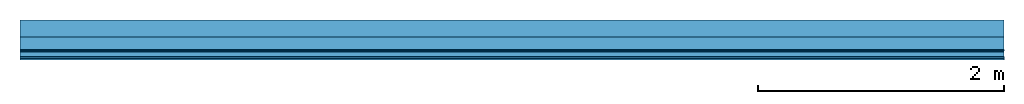
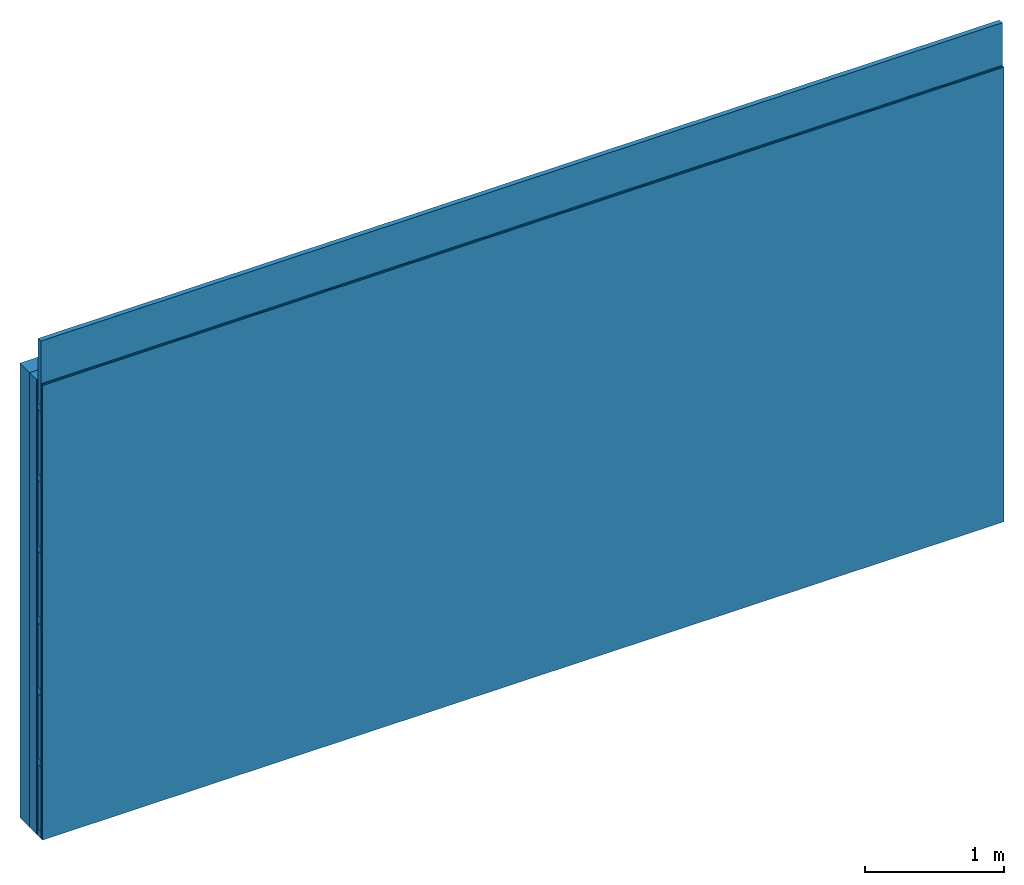
# One storey: 4 plates, 3 members, 1 element without a shape of its own.
"""IFC4 building model written with IfcOpenShell, lengths in metres."""

from ifc_helpers import new_model, si_unit, derived_unit, direction, frame, frame_2d, origin, origin_with_axes, place, context, project, spatial, rectangle, extrude, material, layer, layer_set, type_object, element, aggregate, save


model = new_model("IFC4")

# Units and contexts
plan_context = context("Plan", 3, precision=1e-05, world=origin(), true_north=direction((0.0, 1.0)))
model_context = context("Model", 3, precision=1e-05, world=origin(), true_north=direction((0.0, 1.0)))
ifc_project = project(units=[si_unit("LENGTHUNIT", "METRE"), derived_unit("SOUNDPRESSUREUNIT", [(si_unit("PRESSUREUNIT", "PASCAL", prefix="MICRO"), 0)]), si_unit("ENERGYUNIT", "JOULE", prefix="MEGA"), si_unit("MASSUNIT", "GRAM", prefix="KILO"), derived_unit("THERMALTRANSMITTANCEUNIT", [(si_unit("POWERUNIT", "WATT"), 1), (si_unit("AREAUNIT", "SQUARE_METRE"), -1), (si_unit("THERMODYNAMICTEMPERATUREUNIT", "KELVIN"), -1)]), derived_unit("AREADENSITYUNIT", [(si_unit("MASSUNIT", "GRAM", prefix="KILO"), 1), (si_unit("AREAUNIT", "SQUARE_METRE"), -1)]), derived_unit("USERDEFINED", [(si_unit("ENERGYUNIT", "JOULE", prefix="MEGA"), 1), (si_unit("AREAUNIT", "SQUARE_METRE"), -1)])], contexts=[plan_context, model_context])

# Site, building, storey
site = spatial("IfcSite", under=ifc_project)
building_placement = place(None, origin())
building = spatial("IfcBuilding", under=site, at=building_placement)
storey_placement = place(building_placement, origin())
storey = spatial("IfcBuildingStorey", under=building, at=storey_placement)

# Wall, members, plates
ifc_material_1 = material(Category="10.008")
ifc_layer_1 = layer(ifc_material_1, 0.14, Name="outside 1st layer")
ifc_material_2 = material(Name="of the art")
ifc_layer_2 = layer(ifc_material_2, 0.0, Name="Bond")
ifc_layer_3 = layer(None, 0.1, Name="Support")
ifc_material_3 = material(Name="Air")
ifc_layer_4 = layer(ifc_material_3, 0.01, Name="Coupling")
ifc_layer_5 = layer(None, 0.05, Name="Battens / profiles")
ifc_material_4 = material(Category="03.008")
ifc_layer_6 = layer(ifc_material_4, 0.0125, Name="Covering 1st layer")
ifc_layer_7 = layer(ifc_material_4, 0.0125, Name="Covering 2nd layer")
ifc_layer_set = layer_set([ifc_layer_1, ifc_layer_2, ifc_layer_3, ifc_layer_4, ifc_layer_5, ifc_layer_6, ifc_layer_7])
wall_type = type_object("IfcWallType", Name="D1197", PredefinedType="NOTDEFINED", material=ifc_layer_set)
wall_placement = place(None, frame((0.0, 0.0, 0.0), z_axis=(0.0, -1.0, 0.0), x_axis=(1.0, 0.0, 0.0)))
wall = element("IfcWall", 1, at=wall_placement, inside=storey, type_object=wall_type, material=ifc_layer_set, Name="Wall #1")
ifc_material_5 = material(Name="OSB")
member_1_placement = place(wall_placement, origin())
member_1 = element("IfcMember", 2, at=member_1_placement, material=ifc_material_5, Name="Support", context=plan_context, shape_type="SweptSolid", body=[
    extrude(rectangle(XDim=1.0, YDim=0.1, at=frame_2d((0.5, 0.05), x_axis=(1.0, 0.0))), frame((0.0, 4.0, 0.14), z_axis=(0.0, -1.0, 0.0), x_axis=(1.0, 0.0, 0.0)), (0.0, 0.0, 1.0), 4.0),
    extrude(rectangle(XDim=1.0, YDim=0.1, at=frame_2d((0.5, 0.05), x_axis=(1.0, 0.0))), frame((1.0, 4.0, 0.14), z_axis=(0.0, -1.0, 0.0), x_axis=(1.0, 0.0, 0.0)), (0.0, 0.0, 1.0), 4.0),
    extrude(rectangle(XDim=1.0, YDim=0.1, at=frame_2d((0.5, 0.05), x_axis=(1.0, 0.0))), frame((2.0, 4.0, 0.14), z_axis=(0.0, -1.0, 0.0), x_axis=(1.0, 0.0, 0.0)), (0.0, 0.0, 1.0), 4.0),
    extrude(rectangle(XDim=1.0, YDim=0.1, at=frame_2d((0.5, 0.05), x_axis=(1.0, 0.0))), frame((3.0, 4.0, 0.14), z_axis=(0.0, -1.0, 0.0), x_axis=(1.0, 0.0, 0.0)), (0.0, 0.0, 1.0), 4.0),
    extrude(rectangle(XDim=1.0, YDim=0.1, at=frame_2d((0.5, 0.05), x_axis=(1.0, 0.0))), frame((4.0, 4.0, 0.14), z_axis=(0.0, -1.0, 0.0), x_axis=(1.0, 0.0, 0.0)), (0.0, 0.0, 1.0), 4.0),
    extrude(rectangle(XDim=1.0, YDim=0.1, at=frame_2d((0.5, 0.05), x_axis=(1.0, 0.0))), frame((5.0, 4.0, 0.14), z_axis=(0.0, -1.0, 0.0), x_axis=(1.0, 0.0, 0.0)), (0.0, 0.0, 1.0), 4.0),
    extrude(rectangle(XDim=1.0, YDim=0.1, at=frame_2d((0.5, 0.05), x_axis=(1.0, 0.0))), frame((6.0, 4.0, 0.14), z_axis=(0.0, -1.0, 0.0), x_axis=(1.0, 0.0, 0.0)), (0.0, 0.0, 1.0), 4.0),
    extrude(rectangle(XDim=1.0, YDim=0.1, at=frame_2d((0.5, 0.05), x_axis=(1.0, 0.0))), frame((7.0, 4.0, 0.14), z_axis=(0.0, -1.0, 0.0), x_axis=(1.0, 0.0, 0.0)), (0.0, 0.0, 1.0), 4.0),
])
ifc_material_6 = material()
member_2_placement = place(wall_placement, origin())
member_2 = element("IfcMember", 3, at=member_2_placement, material=ifc_material_6, Name="Battens / profiles", context=plan_context, shape_type="SweptSolid", body=[
    extrude(rectangle(XDim=0.06, YDim=0.05, at=frame_2d((0.03, 0.025), x_axis=(1.0, 0.0))), frame((0.0, 0.0, 0.25), z_axis=(1.0, 0.0, 0.0), x_axis=(0.0, 1.0, 0.0)), (0.0, 0.0, 1.0), 8.0),
    extrude(rectangle(XDim=0.06, YDim=0.05, at=frame_2d((0.03, 0.025), x_axis=(1.0, 0.0))), frame((0.0, 0.625, 0.25), z_axis=(1.0, 0.0, 0.0), x_axis=(0.0, 1.0, 0.0)), (0.0, 0.0, 1.0), 8.0),
    extrude(rectangle(XDim=0.06, YDim=0.05, at=frame_2d((0.03, 0.025), x_axis=(1.0, 0.0))), frame((0.0, 1.25, 0.25), z_axis=(1.0, 0.0, 0.0), x_axis=(0.0, 1.0, 0.0)), (0.0, 0.0, 1.0), 8.0),
    extrude(rectangle(XDim=0.06, YDim=0.05, at=frame_2d((0.03, 0.025), x_axis=(1.0, 0.0))), frame((0.0, 1.875, 0.25), z_axis=(1.0, 0.0, 0.0), x_axis=(0.0, 1.0, 0.0)), (0.0, 0.0, 1.0), 8.0),
    extrude(rectangle(XDim=0.06, YDim=0.05, at=frame_2d((0.03, 0.025), x_axis=(1.0, 0.0))), frame((0.0, 2.5, 0.25), z_axis=(1.0, 0.0, 0.0), x_axis=(0.0, 1.0, 0.0)), (0.0, 0.0, 1.0), 8.0),
    extrude(rectangle(XDim=0.06, YDim=0.05, at=frame_2d((0.03, 0.025), x_axis=(1.0, 0.0))), frame((0.0, 3.125, 0.25), z_axis=(1.0, 0.0, 0.0), x_axis=(0.0, 1.0, 0.0)), (0.0, 0.0, 1.0), 8.0),
    extrude(rectangle(XDim=0.06, YDim=0.05, at=frame_2d((0.03, 0.025), x_axis=(1.0, 0.0))), frame((0.0, 3.75, 0.25), z_axis=(1.0, 0.0, 0.0), x_axis=(0.0, 1.0, 0.0)), (0.0, 0.0, 1.0), 8.0),
])
ifc_material_7 = material(Name="MINERAL PLUS KP 034")
member_3_placement = place(wall_placement, origin())
member_3 = element("IfcMember", 4, at=member_3_placement, material=ifc_material_7, Name="Cavity", context=plan_context, shape_type="SweptSolid", body=[
    extrude(rectangle(XDim=0.565, YDim=0.04, at=frame_2d((0.2825, 0.02), x_axis=(1.0, 0.0))), frame((0.0, 0.06, 0.26), z_axis=(1.0, 0.0, 0.0), x_axis=(0.0, 1.0, 0.0)), (0.0, 0.0, 1.0), 8.0),
    extrude(rectangle(XDim=0.565, YDim=0.04, at=frame_2d((0.2825, 0.02), x_axis=(1.0, 0.0))), frame((0.0, 0.685, 0.26), z_axis=(1.0, 0.0, 0.0), x_axis=(0.0, 1.0, 0.0)), (0.0, 0.0, 1.0), 8.0),
    extrude(rectangle(XDim=0.565, YDim=0.04, at=frame_2d((0.2825, 0.02), x_axis=(1.0, 0.0))), frame((0.0, 1.31, 0.26), z_axis=(1.0, 0.0, 0.0), x_axis=(0.0, 1.0, 0.0)), (0.0, 0.0, 1.0), 8.0),
    extrude(rectangle(XDim=0.565, YDim=0.04, at=frame_2d((0.2825, 0.02), x_axis=(1.0, 0.0))), frame((0.0, 1.935, 0.26), z_axis=(1.0, 0.0, 0.0), x_axis=(0.0, 1.0, 0.0)), (0.0, 0.0, 1.0), 8.0),
    extrude(rectangle(XDim=0.565, YDim=0.04, at=frame_2d((0.2825, 0.02), x_axis=(1.0, 0.0))), frame((0.0, 2.56, 0.26), z_axis=(1.0, 0.0, 0.0), x_axis=(0.0, 1.0, 0.0)), (0.0, 0.0, 1.0), 8.0),
    extrude(rectangle(XDim=0.565, YDim=0.04, at=frame_2d((0.2825, 0.02), x_axis=(1.0, 0.0))), frame((0.0, 3.185, 0.26), z_axis=(1.0, 0.0, 0.0), x_axis=(0.0, 1.0, 0.0)), (0.0, 0.0, 1.0), 8.0),
    extrude(rectangle(XDim=0.565, YDim=0.04, at=frame_2d((0.2825, 0.02), x_axis=(1.0, 0.0))), frame((0.0, 3.81, 0.26), z_axis=(1.0, 0.0, 0.0), x_axis=(0.0, 1.0, 0.0)), (0.0, 0.0, 1.0), 8.0),
])
plate_1_placement = place(wall_placement, origin())
plate_1 = element("IfcPlate", 5, at=plate_1_placement, material=ifc_material_1, Name="outside 1st layer", context=plan_context, shape_type="SweptSolid", body=[
    extrude(rectangle(XDim=8.0, YDim=4.0, at=frame_2d((4.0, 2.0), x_axis=(1.0, 0.0))), origin_with_axes(), (0.0, 0.0, 1.0), 0.14),
])
plate_2_placement = place(wall_placement, origin())
plate_2 = element("IfcPlate", 6, at=plate_2_placement, material=ifc_material_3, Name="Coupling", context=plan_context, shape_type="SweptSolid", body=[
    extrude(rectangle(XDim=8.0, YDim=4.0, at=frame_2d((4.0, 2.0), x_axis=(1.0, 0.0))), frame((0.0, 0.0, 0.24), z_axis=(0.0, 0.0, 1.0), x_axis=(1.0, 0.0, 0.0)), (0.0, 0.0, 1.0), 0.01),
])
plate_3_placement = place(wall_placement, origin())
plate_3 = element("IfcPlate", 7, at=plate_3_placement, material=ifc_material_4, Name="Covering 1st layer", context=plan_context, shape_type="SweptSolid", body=[
    extrude(rectangle(XDim=8.0, YDim=4.0, at=frame_2d((4.0, 2.0), x_axis=(1.0, 0.0))), frame((0.0, 0.0, 0.3), z_axis=(0.0, 0.0, 1.0), x_axis=(1.0, 0.0, 0.0)), (0.0, 0.0, 1.0), 0.0125),
])
plate_4_placement = place(wall_placement, origin())
plate_4 = element("IfcPlate", 8, at=plate_4_placement, material=ifc_material_4, Name="Covering 2nd layer", context=plan_context, shape_type="SweptSolid", body=[
    extrude(rectangle(XDim=8.0, YDim=4.0, at=frame_2d((4.0, 2.0), x_axis=(1.0, 0.0))), frame((0.0, 0.0, 0.3125), z_axis=(0.0, 0.0, 1.0), x_axis=(1.0, 0.0, 0.0)), (0.0, 0.0, 1.0), 0.0125),
])
aggregate(wall, [plate_1, member_1, plate_2, member_2, member_3, plate_3, plate_4])

save(model, "model.ifc")
